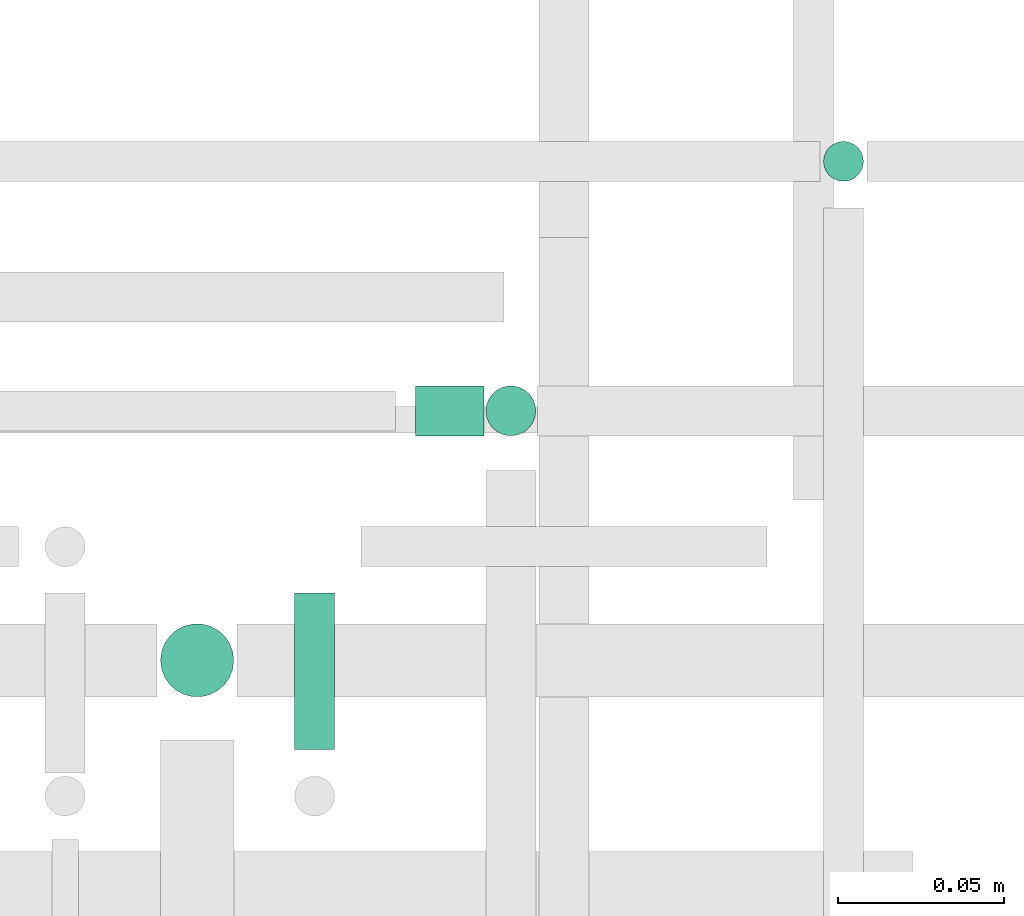
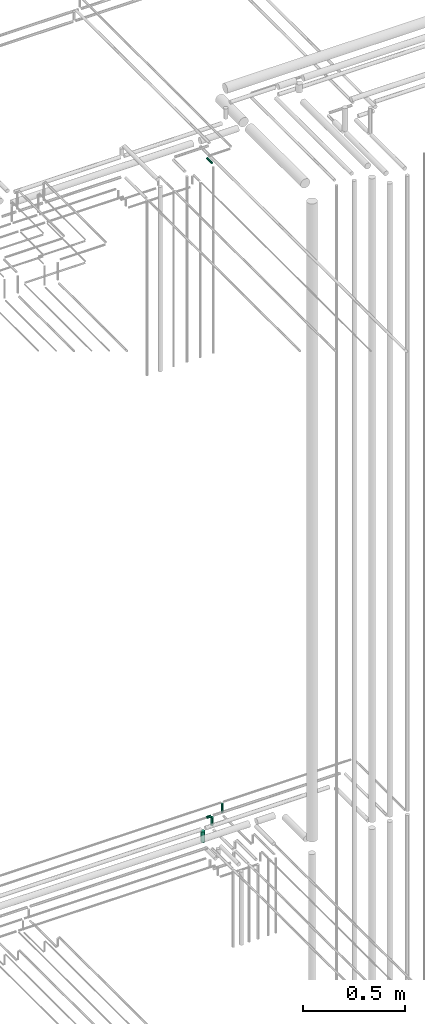
# One storey, part 300 of 331: 5 flow segments.
"""IFC2X3 building model written with IfcOpenShell, lengths in millimetres."""

from ifc_helpers import new_model, entity, si_unit, converted_unit, derived_unit, direction, frame, frame_2d, origin, origin_2d_with_axis, place, context, subcontext, project, spatial, circle, extrude, type_object, element, save


model = new_model("IFC2X3")

# Units and contexts
model_context = context("Model", 3, precision=0.01, world=origin(), true_north=direction((6.12303176911189e-17, 1.0)))
body_context = subcontext(model_context, "Body", "Model", "MODEL_VIEW")
ifc_project = project(units=[si_unit("LENGTHUNIT", "METRE", prefix="MILLI"), si_unit("AREAUNIT", "SQUARE_METRE"), si_unit("VOLUMEUNIT", "CUBIC_METRE"), converted_unit("PLANEANGLEUNIT", "DEGREE", entity("IfcRatioMeasure", 0.0174532925199433), si_unit("PLANEANGLEUNIT", "RADIAN"), dimensions=[0, 0, 0, 0, 0, 0, 0]), si_unit("MASSUNIT", "GRAM", prefix="KILO"), derived_unit("MASSDENSITYUNIT", [(si_unit("MASSUNIT", "GRAM", prefix="KILO"), 1), (si_unit("LENGTHUNIT", "METRE"), -3)]), derived_unit("MOMENTOFINERTIAUNIT", [(si_unit("LENGTHUNIT", "METRE"), 4)]), si_unit("TIMEUNIT", "SECOND"), si_unit("FREQUENCYUNIT", "HERTZ"), si_unit("THERMODYNAMICTEMPERATUREUNIT", "DEGREE_CELSIUS"), derived_unit("THERMALTRANSMITTANCEUNIT", [(si_unit("MASSUNIT", "GRAM", prefix="KILO"), 1), (si_unit("THERMODYNAMICTEMPERATUREUNIT", "KELVIN"), -1), (si_unit("TIMEUNIT", "SECOND"), -3)]), derived_unit("VOLUMETRICFLOWRATEUNIT", [(si_unit("LENGTHUNIT", "METRE"), 3), (si_unit("TIMEUNIT", "SECOND"), -1)]), derived_unit("MASSFLOWRATEUNIT", [(si_unit("MASSUNIT", "GRAM", prefix="KILO"), 1), (si_unit("TIMEUNIT", "SECOND"), -1)]), derived_unit("ROTATIONALFREQUENCYUNIT", [(si_unit("TIMEUNIT", "SECOND"), -1)]), si_unit("ELECTRICCURRENTUNIT", "AMPERE"), si_unit("ELECTRICVOLTAGEUNIT", "VOLT"), si_unit("POWERUNIT", "WATT"), si_unit("FORCEUNIT", "NEWTON", prefix="KILO"), si_unit("ILLUMINANCEUNIT", "LUX"), si_unit("LUMINOUSFLUXUNIT", "LUMEN"), si_unit("LUMINOUSINTENSITYUNIT", "CANDELA"), derived_unit("USERDEFINED", [(si_unit("MASSUNIT", "GRAM", prefix="KILO"), -1), (si_unit("LENGTHUNIT", "METRE"), -2), (si_unit("TIMEUNIT", "SECOND"), 3), (si_unit("LUMINOUSFLUXUNIT", "LUMEN"), 1)]), derived_unit("LINEARVELOCITYUNIT", [(si_unit("LENGTHUNIT", "METRE"), 1), (si_unit("TIMEUNIT", "SECOND"), -1)]), si_unit("PRESSUREUNIT", "PASCAL"), derived_unit("USERDEFINED", [(si_unit("LENGTHUNIT", "METRE"), -2), (si_unit("MASSUNIT", "GRAM", prefix="KILO"), 1), (si_unit("TIMEUNIT", "SECOND"), -2)]), derived_unit("LINEARFORCEUNIT", [(si_unit("MASSUNIT", "GRAM", prefix="KILO"), 1), (si_unit("LENGTHUNIT", "METRE"), 1), (si_unit("TIMEUNIT", "SECOND"), -2), (si_unit("LENGTHUNIT", "METRE"), -1)]), derived_unit("PLANARFORCEUNIT", [(si_unit("MASSUNIT", "GRAM", prefix="KILO"), 1), (si_unit("LENGTHUNIT", "METRE"), 1), (si_unit("TIMEUNIT", "SECOND"), -2), (si_unit("LENGTHUNIT", "METRE"), -2)])], contexts=[model_context])

# Site, building, storey
site_placement = place(None, frame((0.0, -0.00077364408347762, 0.0)))
site = spatial("IfcSite", under=ifc_project, at=site_placement, CompositionType="ELEMENT")
building_placement = place(site_placement, origin())
building = spatial("IfcBuilding", under=site, at=building_placement, CompositionType="ELEMENT")
storey_placement = place(building_placement, origin())
storey = spatial("IfcBuildingStorey", under=building, at=storey_placement, CompositionType="ELEMENT", Elevation=0.0)

# Flow segments
pipe_segment_type = type_object("IfcPipeSegmentType", PredefinedType="NOTDEFINED")
flow_segment_1_placement = place(storey_placement, frame((63502.5166110417, 8668.02529159145, 14489.0)))
element("IfcFlowSegment", 1, at=flow_segment_1_placement, inside=storey, type_object=pipe_segment_type, context=body_context, shape_type="SweptSolid", body=[
    extrude(circle(Radius=6.0, at=frame_2d((0.0, 1.08286712929839e-12), x_axis=(1.0, 0.0))), frame((7.59527223591454, 7.59527223591454, 0.0)), (0.0, 0.0, 1.0), 53.9999999999986),
])
flow_segment_2_placement = place(storey_placement, frame((63381.4440163066, 8591.52529159146, 14540.9047277641)))
element("IfcFlowSegment", 2, at=flow_segment_2_placement, inside=storey, type_object=pipe_segment_type, context=body_context, shape_type="SweptSolid", body=[
    extrude(circle(Radius=7.5, at=frame_2d((0.0, -2.16573425859679e-12), x_axis=(1.0, 0.0))), frame((0.0, 9.09527223591636, 9.09527223591853), z_axis=(1.0, 0.0, 0.0), x_axis=(0.0, 1.0, 0.0)), (0.0, 0.0, 1.0), 20.6645186418983),
])
flow_segment_3_placement = place(storey_placement, frame((63401.0132627126, 8591.52529159146, 14493.0)))
element("IfcFlowSegment", 3, at=flow_segment_3_placement, inside=storey, type_object=pipe_segment_type, context=body_context, shape_type="SweptSolid", body=[
    extrude(circle(Radius=7.5, at=origin_2d_with_axis()), frame((9.09527223591419, 9.09527223591636, 0.0)), (0.0, 0.0, 1.0), 49.0000000000149),
])
flow_segment_4_placement = place(storey_placement, frame((63303.2157915365, 8513.02529159144, 14474.0)))
element("IfcFlowSegment", 4, at=flow_segment_4_placement, inside=storey, type_object=pipe_segment_type, context=body_context, shape_type="SweptSolid", body=[
    extrude(circle(Radius=11.0, at=origin_2d_with_axis()), frame((12.5952722359134, 12.5952722359156, 0.0)), (0.0, 0.0, 1.0), 63.9999999999963),
])
flow_segment_5_placement = place(storey_placement, frame((63343.5166110417, 8498.81073448244, 18517.4047277641)))
element("IfcFlowSegment", 5, at=flow_segment_5_placement, inside=storey, type_object=pipe_segment_type, context=body_context, shape_type="SweptSolid", body=[
    extrude(circle(Radius=6.0, at=origin_2d_with_axis()), frame((7.59527223591454, 0.0, 7.5952722359167), z_axis=(0.0, 1.0, 0.0), x_axis=(1.0, 0.0, 0.0)), (0.0, 0.0, 1.0), 47.0000000000023),
])

save(model, "model.ifc")
